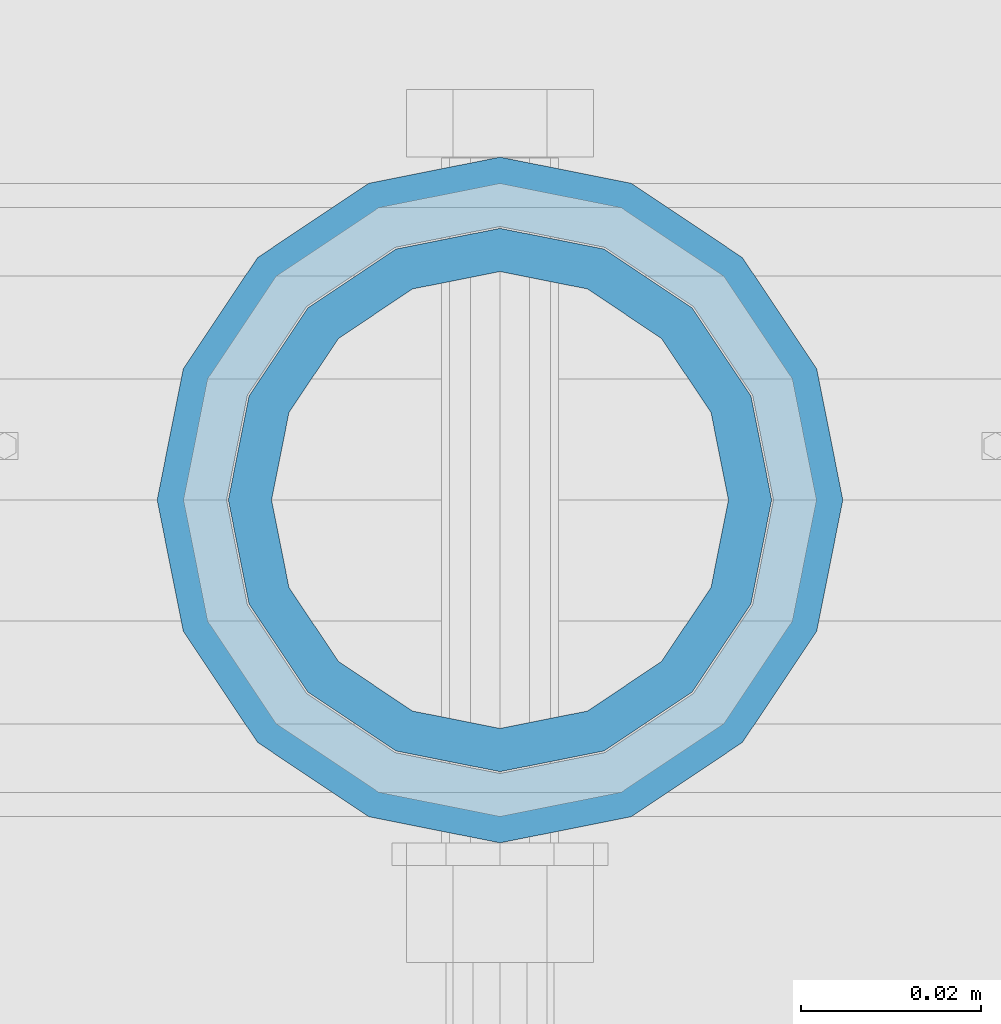
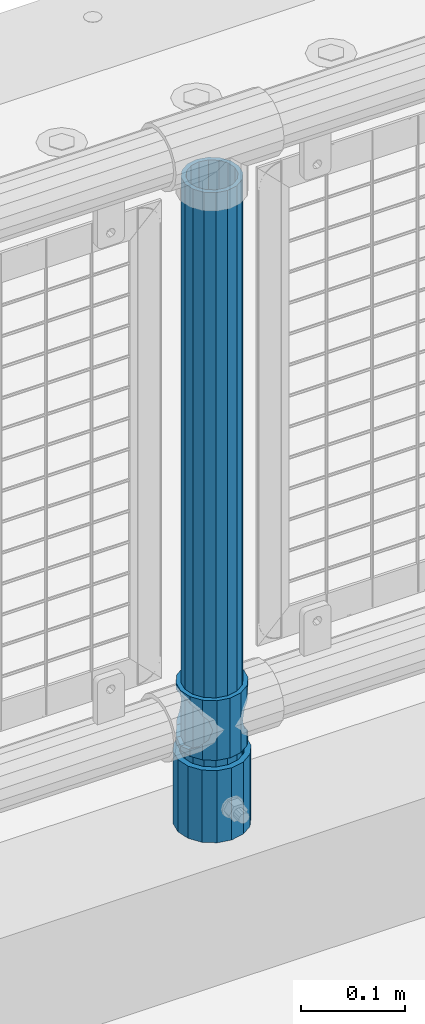
# One storey, part 70 of 270: 3 columns.
"""IFC2X3 building model written with IfcOpenShell, lengths in millimetres."""

from ifc_helpers import new_model, si_unit, frame, origin_with_axes, place, context, subcontext, project, spatial, faceted_brep, material, type_object, element, save


model = new_model("IFC2X3")

# Units and contexts
model_context = context("Model", 3, precision=1e-05, world=origin_with_axes())
body_context = subcontext(model_context, "Body", "Model", "MODEL_VIEW")
ifc_project = project(units=[si_unit("LENGTHUNIT", "METRE", prefix="MILLI"), si_unit("AREAUNIT", "SQUARE_METRE"), si_unit("VOLUMEUNIT", "CUBIC_METRE"), si_unit("MASSUNIT", "GRAM", prefix="KILO"), si_unit("TIMEUNIT", "SECOND"), si_unit("PLANEANGLEUNIT", "RADIAN"), si_unit("SOLIDANGLEUNIT", "STERADIAN"), si_unit("THERMODYNAMICTEMPERATUREUNIT", "DEGREE_CELSIUS"), si_unit("LUMINOUSINTENSITYUNIT", "LUMEN")], contexts=[model_context])

# Site, building, storey
site_placement = place(None, origin_with_axes())
site = spatial("IfcSite", under=ifc_project, at=site_placement, CompositionType="ELEMENT")
building_placement = place(site_placement, origin_with_axes())
building = spatial("IfcBuilding", under=site, at=building_placement, Name="Standard", CompositionType="ELEMENT")
storey_placement = place(building_placement, origin_with_axes())
storey = spatial("IfcBuildingStorey", under=building, at=storey_placement, Name="Undefined", CompositionType="ELEMENT", Elevation=0.0)

# Columns
ifc_material_1 = material()
column_type_1 = type_object("IfcColumnType", PredefinedType="NOTDEFINED")
column_1_placement = place(storey_placement, frame((2254.0, -16335.5, 168.02), z_axis=(-1.0, 0.0, 0.0), x_axis=(0.0, 0.0, 1.0)))
element("IfcColumn", 1, at=column_1_placement, inside=storey, type_object=column_type_1, material=ifc_material_1, context=body_context, shape_type="Brep", body=[
    faceted_brep([(0.0, -25.3500000000004, 0.0), (0.0, -23.4203461491616, 9.70102501045403), (760.0, -23.4203461491616, 9.70102501045403), (760.0, -25.3500000000004, 0.0), (0.0, -17.9251569030785, 17.9251569030785), (760.0, -17.9251569030785, 17.9251569030785), (0.0, -9.70102501045585, 23.4203461491597), (760.0, -9.70102501045585, 23.4203461491597), (0.0, 0.0, 25.3499999999985), (760.0, 0.0, 25.3499999999985), (0.0, 9.70102501045585, 23.4203461491597), (760.0, 9.70102501045585, 23.4203461491597), (0.0, 17.9251569030785, 17.9251569030785), (760.0, 17.9251569030785, 17.9251569030785), (0.0, 23.4203461491616, 9.70102501045403), (760.0, 23.4203461491616, 9.70102501045403), (0.0, 25.3500000000004, 0.0), (760.0, 25.3500000000004, 0.0), (0.0, 23.4203461491616, -9.70102501045403), (760.0, 23.4203461491616, -9.70102501045403), (0.0, 17.9251569030785, -17.9251569030785), (760.0, 17.9251569030785, -17.9251569030785), (0.0, 9.70102501045585, -23.4203461491597), (760.0, 9.70102501045585, -23.4203461491597), (0.0, 0.0, -25.3499999999985), (760.0, 0.0, -25.3499999999985), (0.0, -9.70102501045585, -23.4203461491597), (760.0, -9.70102501045585, -23.4203461491597), (0.0, -17.9251569030785, -17.9251569030785), (760.0, -17.9251569030785, -17.9251569030785), (0.0, -23.4203461491616, -9.70102501045403), (760.0, -23.4203461491616, -9.70102501045403), (0.0, -30.1499999999996, 0.0), (0.0, -27.8549679052157, -11.5379054858058), (760.0, -27.8549679052157, -11.5379054858058), (760.0, -30.1499999999996, 0.0), (0.0, -21.3192694527752, -21.3192694527752), (760.0, -21.3192694527752, -21.3192694527752), (0.0, -11.5379054858076, -27.8549679052157), (760.0, -11.5379054858076, -27.8549679052157), (0.0, 0.0, -30.1500000000015), (760.0, 0.0, -30.1500000000015), (0.0, 11.5379054858076, -27.8549679052157), (760.0, 11.5379054858076, -27.8549679052157), (0.0, 21.3192694527752, -21.3192694527752), (760.0, 21.3192694527752, -21.3192694527752), (0.0, 27.8549679052157, -11.5379054858058), (760.0, 27.8549679052157, -11.5379054858058), (0.0, 30.1499999999996, 0.0), (760.0, 30.1499999999996, 0.0), (0.0, 27.8549679052157, 11.5379054858058), (760.0, 27.8549679052157, 11.5379054858058), (0.0, 21.3192694527752, 21.3192694527752), (760.0, 21.3192694527752, 21.3192694527752), (0.0, 11.5379054858076, 27.8549679052157), (760.0, 11.5379054858076, 27.8549679052157), (0.0, 0.0, 30.1500000000015), (760.0, 0.0, 30.1500000000015), (0.0, -11.5379054858076, 27.8549679052157), (760.0, -11.5379054858076, 27.8549679052157), (0.0, -21.3192694527752, 21.3192694527752), (760.0, -21.3192694527752, 21.3192694527752), (0.0, -27.8549679052157, 11.5379054858058), (760.0, -27.8549679052157, 11.5379054858058)], [[[0, 1, 2, 3]], [[1, 4, 5, 2]], [[4, 6, 7, 5]], [[6, 8, 9, 7]], [[8, 10, 11, 9]], [[10, 12, 13, 11]], [[12, 14, 15, 13]], [[14, 16, 17, 15]], [[16, 18, 19, 17]], [[18, 20, 21, 19]], [[20, 22, 23, 21]], [[22, 24, 25, 23]], [[24, 26, 27, 25]], [[26, 28, 29, 27]], [[28, 30, 31, 29]], [[30, 0, 3, 31]], [[32, 33, 34, 35]], [[33, 36, 37, 34]], [[36, 38, 39, 37]], [[38, 40, 41, 39]], [[40, 42, 43, 41]], [[42, 44, 45, 43]], [[44, 46, 47, 45]], [[46, 48, 49, 47]], [[48, 50, 51, 49]], [[50, 52, 53, 51]], [[52, 54, 55, 53]], [[54, 56, 57, 55]], [[56, 58, 59, 57]], [[58, 60, 61, 59]], [[60, 62, 63, 61]], [[62, 32, 35, 63]], [[37, 39, 41, 43, 45, 47, 49, 51, 53, 55, 57, 59, 61, 63, 35, 34], [5, 7, 9, 11, 13, 15, 17, 19, 21, 23, 25, 27, 29, 31, 3, 2]], [[62, 60, 58, 56, 54, 52, 50, 48, 46, 44, 42, 40, 38, 36, 33, 32], [30, 28, 26, 24, 22, 20, 18, 16, 14, 12, 10, 8, 6, 4, 1, 0]]]),
])
column_type_2 = type_object("IfcColumnType", PredefinedType="NOTDEFINED")
column_2_placement = place(storey_placement, frame((2254.0, -16335.5, 168.02), z_axis=(0.0, 1.0, 0.0), x_axis=(0.0, 0.0, 1.0)))
element("IfcColumn", 2, at=column_2_placement, inside=storey, type_object=column_type_2, material=ifc_material_1, context=body_context, shape_type="Brep", body=[
    faceted_brep([(0.0, -31.75, 0.0), (0.0, -29.3331751572332, 12.1501989775916), (85.0, -29.3331751572332, 12.1501989775916), (85.0, -31.75, 0.0), (0.0, -22.4506403026717, 22.4506403026735), (85.0, -22.4506403026717, 22.4506403026735), (0.0, -12.1501989775934, 29.3331751572332), (85.0, -12.1501989775934, 29.3331751572332), (0.0, 0.0, 31.75), (85.0, 0.0, 31.75), (0.0, 12.1501989775934, 29.3331751572332), (85.0, 12.1501989775934, 29.3331751572332), (0.0, 22.4506403026717, 22.4506403026735), (85.0, 22.4506403026717, 22.4506403026735), (0.0, 29.3331751572332, 12.1501989775916), (85.0, 29.3331751572332, 12.1501989775916), (0.0, 31.75, 0.0), (85.0, 31.75, 0.0), (0.0, 29.3331751572332, -12.1501989775916), (85.0, 29.3331751572332, -12.1501989775916), (0.0, 22.4506403026717, -22.4506403026735), (85.0, 22.4506403026717, -22.4506403026735), (0.0, 12.1501989775934, -29.3331751572332), (85.0, 12.1501989775934, -29.3331751572332), (0.0, 0.0, -31.75), (85.0, 0.0, -31.75), (0.0, -12.1501989775934, -29.3331751572332), (85.0, -12.1501989775934, -29.3331751572332), (0.0, -22.4506403026717, -22.4506403026735), (85.0, -22.4506403026717, -22.4506403026735), (0.0, -29.3331751572332, -12.1501989775916), (85.0, -29.3331751572332, -12.1501989775916), (0.0, -38.0499999999993, 0.0), (0.0, -35.1536162120537, -14.561104601491), (85.0, -35.1536162120537, -14.561104601491), (85.0, -38.0499999999993, 0.0), (0.0, -26.9054130241493, -26.9054130241475), (85.0, -26.9054130241493, -26.9054130241475), (0.0, -14.5611046014928, -35.1536162120537), (85.0, -14.5611046014928, -35.1536162120537), (0.0, 0.0, -38.0499999999993), (85.0, 0.0, -38.0499999999993), (0.0, 14.5611046014928, -35.1536162120537), (85.0, 14.5611046014928, -35.1536162120537), (0.0, 26.9054130241493, -26.9054130241475), (85.0, 26.9054130241493, -26.9054130241475), (0.0, 35.1536162120537, -14.561104601491), (85.0, 35.1536162120537, -14.561104601491), (0.0, 38.0499999999993, 0.0), (85.0, 38.0499999999993, 0.0), (0.0, 35.1536162120537, 14.561104601491), (85.0, 35.1536162120537, 14.561104601491), (0.0, 26.9054130241493, 26.9054130241475), (85.0, 26.9054130241493, 26.9054130241475), (0.0, 14.5611046014928, 35.1536162120537), (85.0, 14.5611046014928, 35.1536162120537), (0.0, 0.0, 38.0499999999993), (85.0, 0.0, 38.0499999999993), (0.0, -14.5611046014928, 35.1536162120537), (85.0, -14.5611046014928, 35.1536162120537), (0.0, -26.9054130241493, 26.9054130241475), (85.0, -26.9054130241493, 26.9054130241475), (0.0, -35.1536162120537, 14.561104601491), (85.0, -35.1536162120537, 14.561104601491)], [[[0, 1, 2, 3]], [[1, 4, 5, 2]], [[4, 6, 7, 5]], [[6, 8, 9, 7]], [[8, 10, 11, 9]], [[10, 12, 13, 11]], [[12, 14, 15, 13]], [[14, 16, 17, 15]], [[16, 18, 19, 17]], [[18, 20, 21, 19]], [[20, 22, 23, 21]], [[22, 24, 25, 23]], [[24, 26, 27, 25]], [[26, 28, 29, 27]], [[28, 30, 31, 29]], [[30, 0, 3, 31]], [[32, 33, 34, 35]], [[33, 36, 37, 34]], [[36, 38, 39, 37]], [[38, 40, 41, 39]], [[40, 42, 43, 41]], [[42, 44, 45, 43]], [[44, 46, 47, 45]], [[46, 48, 49, 47]], [[48, 50, 51, 49]], [[50, 52, 53, 51]], [[52, 54, 55, 53]], [[54, 56, 57, 55]], [[56, 58, 59, 57]], [[58, 60, 61, 59]], [[60, 62, 63, 61]], [[62, 32, 35, 63]], [[37, 39, 41, 43, 45, 47, 49, 51, 53, 55, 57, 59, 61, 63, 35, 34], [5, 7, 9, 11, 13, 15, 17, 19, 21, 23, 25, 27, 29, 31, 3, 2]], [[62, 60, 58, 56, 54, 52, 50, 48, 46, 44, 42, 40, 38, 36, 33, 32], [30, 28, 26, 24, 22, 20, 18, 16, 14, 12, 10, 8, 6, 4, 1, 0]]]),
])
ifc_material_2 = material(Name="Misc_Undefined")
column_type_3 = type_object("IfcColumnType", PredefinedType="NOTDEFINED")
column_3_placement = place(storey_placement, frame((2254.0, -16335.5, 263.02), z_axis=(-1.0, 0.0, 0.0), x_axis=(0.0, 0.0, 1.0)))
element("IfcColumn", 3, at=column_3_placement, inside=storey, type_object=column_type_3, material=ifc_material_2, context=body_context, shape_type="Brep", body=[
    faceted_brep([(63.1897438117183, 11.6144421722802, -32.8397438117208), (63.1897438117183, 11.6144421722802, -28.0397438117179), (56.6106908090125, 21.4606908090118, -21.46069080901), (56.6106908090125, 21.4606908090118, -27.1226768591005), (61.9623795176767, 13.4513226476338, -32.4743655677703), (46.7644421722812, 28.0397438117179, -11.614442172282), (46.7644421722812, 28.0397438117179, -20.0882031229812), (51.5310424080071, 24.8548033587067, -24.8548033587067), (35.1500000000015, 30.35, 0.0), (35.1500000000008, 30.3500000000004, -16.6306603983612), (23.5355578277203, 28.0397438117179, -11.614442172282), (23.5355578277203, 28.0397438117179, -20.0882031229812), (18.7689575919954, 24.8548033587067, -24.8548033587067), (13.689309190989, 21.4606908090118, -21.46069080901), (13.689309190989, 21.4606908090118, -27.1226768591005), (8.33762048232484, 13.4513226476338, -32.4743655677703), (7.11025618828324, 11.6144421722802, -28.0397438117179), (7.11025618828324, 11.6144421722802, -32.8397438117208), (4.80000000000075, 0.0, -30.3499999999985), (4.80000000000075, 0.0, -35.1500000000015), (7.11025618828319, -11.6144421722802, -28.0397438117179), (7.11025618828319, -11.6144421722802, -32.8397438117172), (13.689309190989, -21.4606908090118, -21.46069080901), (13.689309190989, -21.4606908090118, -27.1226768591041), (8.33762048232484, -13.4513226476338, -32.4743655677703), (23.5355578277203, -28.0397438117179, -11.614442172282), (23.5355578277203, -28.0397438117179, -20.0882031229885), (18.7689575919954, -24.8548033587067, -24.8548033587067), (35.1500000000015, -30.35, 0.0), (35.1500000000008, -30.3500000000004, -16.6306603983721), (46.7644421722812, -28.0397438117179, -11.614442172282), (46.7644421722812, -28.0397438117179, -20.0882031229885), (51.5310424080071, -24.8548033587067, -24.8548033587067), (56.6106908090125, -21.4606908090118, -21.46069080901), (56.6106908090125, -21.4606908090118, -27.1226768591041), (61.9623795176767, -13.4513226476338, -32.4743655677703), (63.1897438117183, -11.6144421722802, -28.0397438117179), (63.1897438117183, -11.6144421722802, -32.8397438117172), (65.5000000000008, 0.0, -30.3499999999985), (65.5000000000008, 0.0, -35.1500000000015), (0.0, -28.0397438117179, -11.614442172282), (0.0, -30.3500000000004, 0.0), (0.0, -21.4606908090118, -21.46069080901), (0.0, -11.6144421722802, -28.0397438117179), (0.0, 0.0, -30.3499999999985), (0.0, 11.6144421722802, -28.0397438117179), (0.0, 21.4606908090118, -21.46069080901), (0.0, 28.0397438117179, -11.614442172282), (0.0, 30.3500000000004, 0.0), (0.0, 28.0397438117179, 11.614442172282), (23.5355578277192, 28.0397438117179, 11.614442172282), (0.0, 21.4606908090118, 21.46069080901), (13.6893091909879, 21.4606908090118, 21.46069080901), (0.0, 11.6144421722802, 28.0397438117179), (7.11025618828211, 11.6144421722802, 28.0397438117179), (0.0, 0.0, 30.3499999999985), (4.79999999999961, 0.0, 30.3499999999985), (0.0, -11.6144421722802, 28.0397438117179), (7.11025618828205, -11.6144421722802, 28.0397438117179), (0.0, -21.4606908090118, 21.46069080901), (13.6893091909879, -21.4606908090118, 21.46069080901), (0.0, -28.0397438117179, 11.614442172282), (23.5355578277191, -28.0397438117179, 11.614442172282), (0.0, -32.4743655677721, 13.4513226476338), (0.0, -35.1499999999996, 0.0), (70.2999999999993, -35.1499999999996, 0.0), (70.2999999999993, -32.4743655677721, 13.4513226476338), (0.0, 13.4513226476338, -32.4743655677703), (0.0, 24.8548033587067, -24.8548033587067), (0.0, 0.0, -35.1499999999996), (0.0, -13.4513226476338, -32.4743655677703), (0.0, -24.8548033587067, -24.8548033587067), (0.0, -24.8548033587067, 24.8548033587067), (0.0, -13.4513226476338, 32.4743655677703), (0.0, 0.0, 35.1499999999996), (0.0, 13.4513226476338, 32.4743655677703), (0.0, 24.8548033587067, 24.8548033587067), (0.0, 32.4743655677721, 13.4513226476338), (0.0, 35.1499999999996, 0.0), (0.0, 32.4743655677721, -13.4513226476338), (0.0, -32.4743655677721, -13.4513226476338), (70.2999999999993, 32.4743655677721, 13.4513226476338), (70.2999999999993, 35.1499999999996, 0.0), (70.2999999999993, 32.4743655677721, -13.4513226476338), (70.2999999999993, 24.8548033587067, -24.8548033587067), (70.2999999999993, 13.4513226476338, -32.4743655677703), (70.2999999999993, 0.0, -35.1500000000015), (70.2999999999993, -13.4513226476338, -32.4743655677703), (70.2999999999993, -24.8548033587067, -24.8548033587067), (70.2999999999993, -32.4743655677721, -13.4513226476338), (70.2999999999993, 28.0397438117179, 11.614442172282), (70.2999999999993, 21.4606908090118, 21.46069080901), (56.6106908090114, 21.4606908090118, 21.46069080901), (46.7644421722801, 28.0397438117179, 11.614442172282), (70.2999999999993, 11.6144421722802, 28.0397438117179), (63.1897438117172, 11.6144421722802, 28.0397438117179), (70.2999999999993, 0.0, 30.3499999999985), (65.4999999999997, 0.0, 30.3499999999985), (70.2999999999993, -11.6144421722802, 28.0397438117179), (63.1897438117172, -11.6144421722802, 28.0397438117179), (70.2999999999993, -21.4606908090118, 21.46069080901), (56.6106908090114, -21.4606908090118, 21.46069080901), (70.2999999999993, -28.0397438117179, 11.614442172282), (46.7644421722801, -28.0397438117179, 11.614442172282), (70.2999999999993, -11.6144421722802, -28.0397438117179), (70.2999999999993, 0.0, -30.3499999999985), (70.2999999999993, -21.4606908090118, -21.46069080901), (70.2999999999993, -28.0397438117179, -11.614442172282), (70.2999999999993, -30.3500000000004, 0.0), (70.2999999999993, 24.8548033587067, 24.8548033587067), (70.2999999999993, 13.4513226476338, 32.4743655677703), (70.2999999999993, 0.0, 35.1500000000015), (70.2999999999993, -13.4513226476338, 32.4743655677703), (70.2999999999993, -24.8548033587067, 24.8548033587067), (70.2999999999993, 30.3500000000004, 0.0), (70.2999999999993, 28.0397438117179, -11.614442172282), (70.2999999999993, 21.4606908090118, -21.46069080901), (70.2999999999993, 11.6144421722802, -28.0397438117179), (61.9623795176767, 13.4513226476338, 32.4743655677703), (51.5310424080039, 24.8548033587067, 24.8548033587067), (56.6106908090114, 21.4606908090118, 27.1226768591041), (65.4999999999997, 0.0, 35.1500000000015), (63.1897438117172, 11.6144421722802, 32.8397438117172), (63.1897438117172, -11.6144421722802, 32.8397438117172), (61.9623795176767, -13.4513226476338, 32.4743655677703), (56.6106908090114, -21.4606908090118, 27.1226768591077), (51.5310424080071, -24.8548033587067, 24.8548033587067), (18.7689575919954, -24.8548033587067, 24.8548033587067), (46.7644421722801, -28.0397438117179, 20.0882031229849), (35.1499999999996, -30.3500000000004, 16.6306603983649), (23.5355578277191, -28.0397438117179, 20.0882031229849), (8.33762048232262, -13.4513226476338, 32.4743655677703), (13.6893091909879, -21.4606908090118, 27.1226768591077), (4.79999999999961, 0.0, 35.1500000000015), (7.11025618828205, -11.6144421722802, 32.8397438117172), (7.11025618828211, 11.6144421722802, 32.8397438117172), (8.33762048232262, 13.4513226476338, 32.4743655677703), (13.6893091909879, 21.4606908090118, 27.1226768591041), (18.7689575919954, 24.8548033587067, 24.8548033587067), (23.5355578277192, 28.0397438117179, 20.0882031229885), (35.1499999999996, 30.3500000000004, 16.6306603983685), (46.7644421722801, 28.0397438117179, 20.0882031229885)], [[[0, 1, 2, 3, 4]], [[3, 2, 5, 6, 7]], [[6, 5, 8, 9]], [[9, 8, 10, 11]], [[12, 11, 10, 13, 14]], [[15, 14, 13, 16, 17]], [[17, 16, 18, 19]], [[19, 18, 20, 21]], [[21, 20, 22, 23, 24]], [[23, 22, 25, 26, 27]], [[26, 25, 28, 29]], [[29, 28, 30, 31]], [[32, 31, 30, 33, 34]], [[35, 34, 33, 36, 37]], [[37, 36, 38, 39]], [[39, 38, 1, 0]], [[40, 41, 28, 25]], [[42, 40, 25, 22]], [[43, 42, 22, 20]], [[44, 43, 20, 18]], [[45, 44, 18, 16]], [[46, 45, 16, 13]], [[47, 46, 13, 10]], [[48, 47, 10, 8]], [[49, 48, 8, 50]], [[51, 49, 50, 52]], [[53, 51, 52, 54]], [[55, 53, 54, 56]], [[57, 55, 56, 58]], [[59, 57, 58, 60]], [[61, 59, 60, 62]], [[41, 61, 62, 28]], [[63, 64, 65, 66]], [[67, 68, 12, 14, 15]], [[69, 67, 15, 17, 19]], [[24, 70, 69, 19, 21]], [[27, 71, 70, 24, 23]], [[63, 72, 73, 74, 75, 76, 77, 78, 79, 68, 67, 69, 70, 71, 80, 64], [40, 42, 43, 44, 45, 46, 47, 48, 49, 51, 53, 55, 57, 59, 61, 41]], [[78, 77, 81, 82]], [[79, 78, 82, 83]], [[68, 79, 83, 84, 7, 6, 9, 11, 12]], [[7, 84, 85, 4, 3]], [[4, 85, 86, 39, 0]], [[87, 88, 32, 34, 35]], [[86, 87, 35, 37, 39]], [[29, 31, 32, 88, 89, 80, 71, 27, 26]], [[64, 80, 89, 65]], [[90, 91, 92, 93]], [[91, 94, 95, 92]], [[94, 96, 97, 95]], [[96, 98, 99, 97]], [[98, 100, 101, 99]], [[100, 102, 103, 101]], [[104, 105, 38, 36]], [[106, 104, 36, 33]], [[107, 106, 33, 30]], [[108, 107, 30, 28]], [[102, 108, 28, 103]], [[88, 87, 86, 85, 84, 83, 82, 81, 109, 110, 111, 112, 113, 66, 65, 89], [100, 98, 96, 94, 91, 90, 114, 115, 116, 117, 105, 104, 106, 107, 108, 102]], [[118, 110, 109, 119, 120]], [[121, 111, 110, 118, 122]], [[112, 111, 121, 123, 124]], [[113, 112, 124, 125, 126]], [[127, 72, 63, 66, 113, 126, 128, 129, 130]], [[131, 73, 72, 127, 132]], [[133, 74, 73, 131, 134]], [[75, 74, 133, 135, 136]], [[76, 75, 136, 137, 138]], [[119, 109, 81, 77, 76, 138, 139, 140, 141]], [[92, 120, 119, 141, 93]], [[95, 122, 118, 120, 92]], [[97, 121, 122, 95]], [[99, 123, 121, 97]], [[101, 125, 124, 123, 99]], [[103, 128, 126, 125, 101]], [[28, 129, 128, 103]], [[62, 130, 129, 28]], [[60, 132, 127, 130, 62]], [[58, 134, 131, 132, 60]], [[56, 133, 134, 58]], [[54, 135, 133, 56]], [[52, 137, 136, 135, 54]], [[50, 139, 138, 137, 52]], [[8, 140, 139, 50]], [[93, 141, 140, 8]], [[114, 90, 93, 8]], [[115, 114, 8, 5]], [[116, 115, 5, 2]], [[117, 116, 2, 1]], [[105, 117, 1, 38]]]),
])

save(model, "model.ifc")
